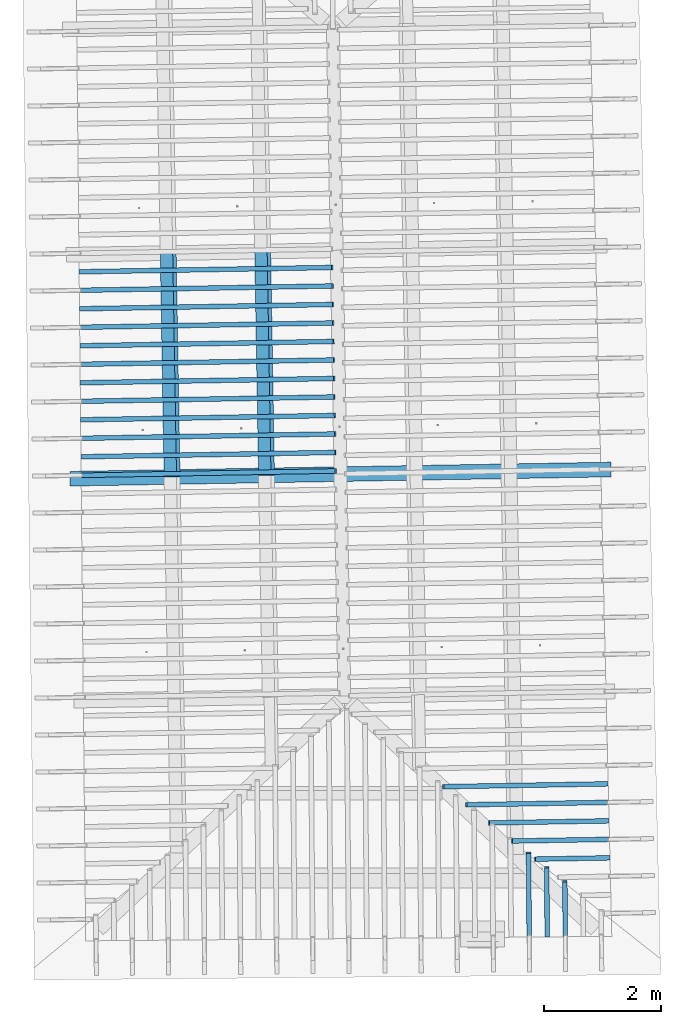
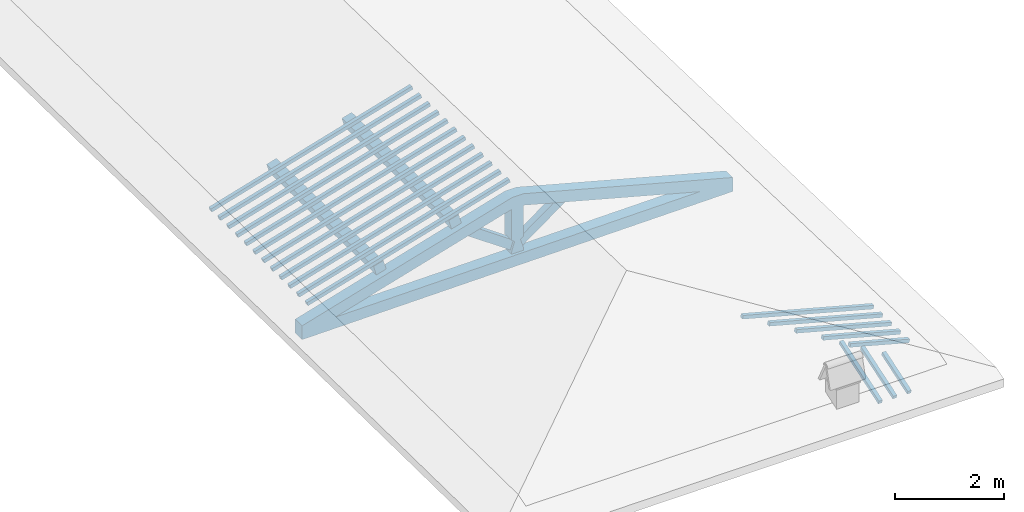
# One storey, part 4 of 19: 21 beams, 2 members, 3 elements without a shape of their own.
"""IFC4 building model written with IfcOpenShell, lengths in metres."""

from ifc_helpers import new_model, entity, si_unit, converted_unit, derived_unit, direction, frame, origin, place, context, subcontext, project, spatial, indexed_curve, outline, extrude, source, transform, mapped, material, type_object, type_shapes, element, aggregate, save


model = new_model("IFC4")

# Units and contexts
model_context = context("Model", 3, precision=1e-05, world=origin(), true_north=direction((6.123233995736766e-17, 1.0)))
body_context = subcontext(model_context, "Body", "Model", "MODEL_VIEW")
ifc_project = project(units=[si_unit("LENGTHUNIT", "METRE"), si_unit("AREAUNIT", "SQUARE_METRE"), si_unit("VOLUMEUNIT", "CUBIC_METRE"), converted_unit("PLANEANGLEUNIT", "DEGREE", entity("IfcPlaneAngleMeasure", 0.017453292519943278), si_unit("PLANEANGLEUNIT", "RADIAN"), dimensions=[0, 0, 0, 0, 0, 0, 0]), derived_unit("THERMALTRANSMITTANCEUNIT", [(si_unit("MASSUNIT", "GRAM", prefix="KILO"), 1), (si_unit("THERMODYNAMICTEMPERATUREUNIT", "KELVIN"), -1), (si_unit("TIMEUNIT", "SECOND"), -3)])], contexts=[model_context])

# Site, building, storey
site_placement = place(None, origin())
site = spatial("IfcSite", under=ifc_project, at=site_placement, CompositionType="ELEMENT")
building_placement = place(site_placement, origin())
building = spatial("IfcBuilding", under=site, at=building_placement, CompositionType="ELEMENT")
storey_placement = place(building_placement, frame((0.0, 0.0, 3.28)))
storey = spatial("IfcBuildingStorey", under=building, at=storey_placement, Name="Livello Copertura", CompositionType="ELEMENT", Elevation=3.28)

# Beam
ifc_material_1 = material(Name="Telaio", Category="Legno")
beam_type_1 = type_object("IfcBeamType", Name="con e 18x18 2", PredefinedType="BEAM", material=ifc_material_1)
shared_shape_1 = source(origin(), body_context, "Body", "SweptSolid", [
    extrude(outline(indexed_curve([(-0.16541753369488893, -2.7162453774766275), (0.08463069471711139, -2.716245377476629), (0.16842467663126645, 1.5495047236372541), (-0.01356084740826559, 1.9493040088108127), (-0.07407699024522271, 1.933682022505188), (-0.16541753369488893, -2.7162453774766275)], self_intersect=False)), frame((-2.713680684761416, -0.12500000000000352, 0.5116016056385222), z_axis=(0.0, 1.0, 0.0), x_axis=(0.24995178089011919, 0.0, -0.9682582853917946)), (0.0, 0.0, 1.0), 0.24999999999999992),
    extrude(outline(indexed_curve([(-2.718970219470431, -0.11203953208496607), (1.9318542149690596, -0.11203953208496614), (1.9486617037575076, -0.05184187166013539), (1.5525136616356172, 0.137960467915034), (-2.7140593608917554, 0.137960467915034), (-2.718970219470431, -0.11203953208496607)], self_intersect=False)), frame((2.7136806847614197, -0.12500000000000352, 0.5116016056385372), z_axis=(0.0, 1.0, 0.0), x_axis=(0.9631625667976574, 0.0, -0.2689198206152686)), (0.0, 0.0, 1.0), 0.24999999999999992),
    extrude(outline(indexed_curve([(-0.5601835339455478, -0.12499999999999746), (-0.49768353394554415, -0.12499999999999749), (-0.2968792817361453, -0.062499999999998515), (-0.2526268150406443, -0.12499999999999746), (0.4434537562213674, -0.12499999999999747), (0.4609040697695109, -0.06249999999999742), (0.7030153386769692, -0.12499999999999746), (0.7030153386769719, 0.1249999999999892), (0.46090406976954656, 0.06249999999999748), (0.4434537562214021, 0.12499999999999911), (-0.2526268150406462, 0.12499999999999915), (-0.29687928173614625, 0.06250000000000018), (-0.4976835339455446, 0.12499999999999908), (-0.5601835339455477, 0.12499999999999911), (-0.5601835339455478, -0.12499999999999746)], self_intersect=False)), frame((0.0, -0.12500000000000397, 0.647683533945542), z_axis=(0.0, 1.0, 0.0), x_axis=(0.0, 0.0, 1.0)), (0.0, 0.0, 1.0), 0.24999999999999992),
    extrude(outline(indexed_curve([(-4.548711713227807, -0.7192326477239056), (-4.505299668811077, -0.9654345859769559), (4.563794928678348, 0.6336914821578127), (4.520382884261614, 0.8798934204108596), (4.107604035615938, 0.7296542061691604), (3.82531022235883, 0.7573333565645375), (-3.8536390513249863, -0.5966725838775957), (-4.109441637550861, -0.7192326477239057), (-4.548711713227807, -0.7192326477239056)], self_intersect=False)), frame((0.0, -0.12500000000000175, -0.0440696120362346), z_axis=(0.0, -1.0, 0.0), x_axis=(0.984807753012208, 0.0, -0.17364817766693108)), (0.0, 0.0, -1.0), 0.24999999999999986),
    extrude(outline(indexed_curve([(0.20359543107977635, -0.4090841915047363), (0.4613119776404389, -0.4090841915047362), (-0.27535475240621304, 0.4973840166014553), (-0.3895526563140025, 0.3207843664080172), (0.20359543107977635, -0.4090841915047363)], self_intersect=False)), frame((0.5239678106288662, -0.07500000000000369, 0.5550133154913391), z_axis=(0.0, 1.0, 0.0), x_axis=(0.9631625667976574, 0.0, -0.2689198206152682)), (0.0, 0.0, 1.0), 0.14999999999999994),
    extrude(outline(indexed_curve([(-0.4613119776404252, -0.4090841915047199), (-0.20359543107976297, -0.4090841915047199), (0.38955265631398844, 0.3207843664080003), (0.2753547524061997, 0.4973840166014395), (-0.4613119776404252, -0.4090841915047199)], self_intersect=False)), frame((-0.5239678106288467, -0.07500000000000369, 0.5550133154913305), z_axis=(0.0, 1.0, 0.0), x_axis=(0.9631625667976591, 0.0, 0.2689198206152626)), (0.0, 0.0, 1.0), 0.15),
])
type_shapes(beam_type_1, [shared_shape_1])
beam_1_placement = place(storey_placement, frame((-0.17369111228995998, 4.725794282128985, -0.3317557506483801), z_axis=(0.0, 0.0, 1.0), x_axis=(0.9998547813867208, 0.017041600221598438, 0.0)))
element("IfcBeam", 1, at=beam_1_placement, inside=storey, type_object=beam_type_1, material=ifc_material_1, Name="con e 18x18 2", ObjectType="con e 18x18 2", PredefinedType="BEAM", context=body_context, shape_type="MappedRepresentation", body=[
    mapped(shared_shape_1, transform((0.0, 0.0, 0.0), scale=1.0)),
])

# Members
ifc_material_2 = material(Name="Legno - Legno da costruzione", Category="Legno")
member_type = type_object("IfcMemberType", Name="Legno:220x220", PredefinedType="PURLIN", material=ifc_material_2)
shared_shape_2 = source(origin(), body_context, "Body", "SweptSolid", [
    extrude(outline(indexed_curve([(-1.905999989737685, -0.11000000000000167), (1.9059999897376847, -0.11000000000000167), (1.905999989737685, 0.11000000000000167), (-1.905999989737685, 0.11000000000000167), (-1.905999989737685, -0.11000000000000167)], self_intersect=False)), frame((1.0262315338316342e-08, 0.0, -0.11000000000000543), z_axis=(0.0, 0.0, 1.0), x_axis=(-1.0, 0.0, 0.0)), (0.0, 0.0, 1.0), 0.21999999999999986),
])
type_shapes(member_type, [shared_shape_2])
for number, where, z_axis, x_axis, name in (
    (2, (-1.4665724231842459, 6.610303913730296, 0.8158581072187941), (-0.2688805697492535, -0.004594467440668277, 0.9631625667976581), (0.01708489701561056, -0.9998540424951863, 0.0), "Legno:220x220"),
    (3, (-3.0746343576136685, 6.582921611877691, 0.3668140609434398), (-0.2688805697492535, -0.004594467440668277, 0.9631625667976581), (0.01708489701561056, -0.9998540424951863, 0.0), "Legno:220x220"),
):
    element("IfcMember", number, at=place(storey_placement, frame(where, z_axis=z_axis, x_axis=x_axis)), inside=storey, type_object=member_type, material=ifc_material_2, Name=name, ObjectType="Legno:220x220", PredefinedType="PURLIN", context=body_context, shape_type="MappedRepresentation", body=[
        mapped(shared_shape_2, transform((0.0, 0.0, 0.0), scale=1.0)),
    ])

# Assembly, beams
assembly_1_placement = place(storey_placement, origin())
assembly_1 = element("IfcElementAssembly", 4, at=assembly_1_placement, inside=storey, Name="Sistema di travi strutturali:Sistema di travi strutturali", ObjectType="Sistema di travi strutturali:Sistema di travi strutturali", AssemblyPlace="NOTDEFINED", PredefinedType="BEAM_GRID")
beam_type_2 = type_object("IfcBeamType", Name="Legno:80x80", PredefinedType="JOIST", material=ifc_material_2)
shared_shape_3 = source(origin(), body_context, "Body", "SweptSolid", [
    extrude(outline(indexed_curve([(-2.233, -0.04000000000000169), (2.233, -0.04000000000000169), (2.233, 0.04000000000000169), (-2.233, 0.04000000000000169), (-2.233, -0.04000000000000169)], self_intersect=False)), frame((0.0, 0.0, -0.040000000000005476), z_axis=(0.0, 0.0, 1.0), x_axis=(-1.0, 0.0, 0.0)), (0.0, 0.0, 1.0), 0.07999999999999997),
])
type_shapes(beam_type_2, [shared_shape_3])
beam_2_placement = place(assembly_1_placement, frame((-2.463337274189889, 8.207578777476792, 0.7009532328972059), z_axis=(-0.2688805697492534, -0.004594467440668275, 0.9631625667976583), x_axis=(0.9630219859926786, 0.016455533263027115, 0.2689198206152653)))
beam_2 = element("IfcBeam", 5, at=beam_2_placement, type_object=beam_type_2, material=ifc_material_2, Name="Legno:80x80", ObjectType="Legno:80x80", PredefinedType="JOIST", context=body_context, shape_type="MappedRepresentation", body=[
    mapped(shared_shape_3, transform((0.0, 0.0, 0.0), scale=1.0)),
])
beam_type_3 = type_object("IfcBeamType", Name="Legno:80x80", PredefinedType="JOIST", material=ifc_material_2)
shared_shape_4 = source(origin(), body_context, "Body", "SweptSolid", [
    extrude(outline(indexed_curve([(-2.234, -0.04000000000000169), (2.234, -0.04000000000000169), (2.234, 0.04000000000000169), (-2.234, 0.04000000000000169), (-2.234, -0.04000000000000169)], self_intersect=False)), frame((0.0, 0.0, -0.040000000000005476), z_axis=(0.0, 0.0, 1.0), x_axis=(-1.0, 0.0, 0.0)), (0.0, 0.0, 1.0), 0.07999999999999997),
])
type_shapes(beam_type_3, [shared_shape_4])
beam_3_placement = place(assembly_1_placement, frame((-2.4591028111552244, 7.892605150076921, 0.7006328599372806), z_axis=(-0.2688805697492536, -0.0045944674406682776, 0.9631625667976582), x_axis=(0.9630219859926786, 0.016455533263027112, 0.26891982061526554)))
beam_3 = element("IfcBeam", 6, at=beam_3_placement, type_object=beam_type_3, material=ifc_material_2, Name="Legno:80x80", ObjectType="Legno:80x80", PredefinedType="JOIST", context=body_context, shape_type="MappedRepresentation", body=[
    mapped(shared_shape_4, transform((0.0, 0.0, 0.0), scale=1.0)),
])
beam_type_4 = type_object("IfcBeamType", Name="Legno:80x80", PredefinedType="JOIST", material=ifc_material_2)
shared_shape_5 = source(origin(), body_context, "Body", "SweptSolid", [
    extrude(outline(indexed_curve([(-2.235, -0.04000000000000169), (2.235, -0.04000000000000169), (2.235, 0.04000000000000169), (-2.235, 0.04000000000000169), (-2.235, -0.04000000000000169)], self_intersect=False)), frame((0.0, 0.0, -0.040000000000005476), z_axis=(0.0, 0.0, 1.0), x_axis=(-1.0, 0.0, 0.0)), (0.0, 0.0, 1.0), 0.07999999999999997),
])
type_shapes(beam_type_4, [shared_shape_5])
beam_4_placement = place(assembly_1_placement, frame((-2.4548683481205593, 7.5776315226770485, 0.7003124869773539), z_axis=(-0.2688805697492534, -0.004594467440668273, 0.9631625667976583), x_axis=(0.9630219859926786, 0.016455533263027122, 0.2689198206152653)))
beam_4 = element("IfcBeam", 7, at=beam_4_placement, type_object=beam_type_4, material=ifc_material_2, Name="Legno:80x80", ObjectType="Legno:80x80", PredefinedType="JOIST", context=body_context, shape_type="MappedRepresentation", body=[
    mapped(shared_shape_5, transform((0.0, 0.0, 0.0), scale=1.0)),
])
beam_type_5 = type_object("IfcBeamType", Name="Legno:80x80", PredefinedType="JOIST", material=ifc_material_2)
shared_shape_6 = source(origin(), body_context, "Body", "SweptSolid", [
    extrude(outline(indexed_curve([(-2.2365, -0.04000000000000169), (2.2365, -0.04000000000000169), (2.2365, 0.04000000000000169), (-2.2365, 0.04000000000000169), (-2.2365, -0.04000000000000169)], self_intersect=False)), frame((0.0, 0.0, -0.040000000000005476), z_axis=(0.0, 0.0, 1.0), x_axis=(-1.0, 0.0, 0.0)), (0.0, 0.0, 1.0), 0.07999999999999997),
])
type_shapes(beam_type_5, [shared_shape_6])
beam_5_placement = place(assembly_1_placement, frame((-2.4506338850858955, 7.262657895277173, 0.6999921140174283), z_axis=(-0.2688805697492536, -0.004594467440668277, 0.9631625667976583), x_axis=(0.9630219859926786, 0.01645553326302712, 0.26891982061526554)))
beam_5 = element("IfcBeam", 8, at=beam_5_placement, type_object=beam_type_5, material=ifc_material_2, Name="Legno:80x80", ObjectType="Legno:80x80", PredefinedType="JOIST", context=body_context, shape_type="MappedRepresentation", body=[
    mapped(shared_shape_6, transform((0.0, 0.0, 0.0), scale=1.0)),
])
beam_type_6 = type_object("IfcBeamType", Name="Legno:80x80", PredefinedType="JOIST", material=ifc_material_2)
shared_shape_7 = source(origin(), body_context, "Body", "SweptSolid", [
    extrude(outline(indexed_curve([(-2.2375, -0.04000000000000169), (2.2375, -0.04000000000000169), (2.2375, 0.04000000000000169), (-2.2375, 0.04000000000000169), (-2.2375, -0.04000000000000169)], self_intersect=False)), frame((0.0, 0.0, -0.040000000000005476), z_axis=(0.0, 0.0, 1.0), x_axis=(-1.0, 0.0, 0.0)), (0.0, 0.0, 1.0), 0.07999999999999997),
])
type_shapes(beam_type_6, [shared_shape_7])
beam_6_placement = place(assembly_1_placement, frame((-2.4463994220512304, 6.947684267877299, 0.6996717410575017), z_axis=(-0.2688805697492535, -0.004594467440668277, 0.9631625667976583), x_axis=(0.9630219859926786, 0.016455533263027143, 0.2689198206152654)))
beam_6 = element("IfcBeam", 9, at=beam_6_placement, type_object=beam_type_6, material=ifc_material_2, Name="Legno:80x80", ObjectType="Legno:80x80", PredefinedType="JOIST", context=body_context, shape_type="MappedRepresentation", body=[
    mapped(shared_shape_7, transform((0.0, 0.0, 0.0), scale=1.0)),
])
beam_type_7 = type_object("IfcBeamType", Name="Legno:80x80", PredefinedType="JOIST", material=ifc_material_2)
shared_shape_8 = source(origin(), body_context, "Body", "SweptSolid", [
    extrude(outline(indexed_curve([(-2.239, -0.04000000000000169), (2.239, -0.04000000000000169), (2.239, 0.04000000000000169), (-2.239, 0.04000000000000169), (-2.239, -0.04000000000000169)], self_intersect=False)), frame((0.0, 0.0, -0.040000000000005476), z_axis=(0.0, 0.0, 1.0), x_axis=(-1.0, 0.0, 0.0)), (0.0, 0.0, 1.0), 0.07999999999999997),
])
type_shapes(beam_type_7, [shared_shape_8])
beam_7_placement = place(assembly_1_placement, frame((-2.4421649590165644, 6.632710640477425, 0.6993513680975754), z_axis=(-0.26888056974925356, -0.0045944674406682776, 0.9631625667976583), x_axis=(0.9630219859926786, 0.016455533263027147, 0.2689198206152655)))
beam_7 = element("IfcBeam", 10, at=beam_7_placement, type_object=beam_type_7, material=ifc_material_2, Name="Legno:80x80", ObjectType="Legno:80x80", PredefinedType="JOIST", context=body_context, shape_type="MappedRepresentation", body=[
    mapped(shared_shape_8, transform((0.0, 0.0, 0.0), scale=1.0)),
])
beam_type_8 = type_object("IfcBeamType", Name="Legno:80x80", PredefinedType="JOIST", material=ifc_material_2)
shared_shape_9 = source(origin(), body_context, "Body", "SweptSolid", [
    extrude(outline(indexed_curve([(-2.24, -0.04000000000000169), (2.24, -0.04000000000000169), (2.24, 0.04000000000000169), (-2.24, 0.04000000000000169), (-2.24, -0.04000000000000169)], self_intersect=False)), frame((0.0, 0.0, -0.040000000000005476), z_axis=(0.0, 0.0, 1.0), x_axis=(-1.0, 0.0, 0.0)), (0.0, 0.0, 1.0), 0.07999999999999997),
])
type_shapes(beam_type_8, [shared_shape_9])
beam_8_placement = place(assembly_1_placement, frame((-2.4379304959819006, 6.317737013077552, 0.6990309951376489), z_axis=(-0.2688805697492535, -0.004594467440668277, 0.9631625667976583), x_axis=(0.9630219859926786, 0.016455533263027153, 0.2689198206152654)))
beam_8 = element("IfcBeam", 11, at=beam_8_placement, type_object=beam_type_8, material=ifc_material_2, Name="Legno:80x80", ObjectType="Legno:80x80", PredefinedType="JOIST", context=body_context, shape_type="MappedRepresentation", body=[
    mapped(shared_shape_9, transform((0.0, 0.0, 0.0), scale=1.0)),
])
beam_type_9 = type_object("IfcBeamType", Name="Legno:80x80", PredefinedType="JOIST", material=ifc_material_2)
shared_shape_10 = source(origin(), body_context, "Body", "SweptSolid", [
    extrude(outline(indexed_curve([(-2.241, -0.04000000000000169), (2.241, -0.04000000000000169), (2.241, 0.04000000000000169), (-2.241, 0.04000000000000169), (-2.241, -0.04000000000000169)], self_intersect=False)), frame((0.0, 0.0, -0.040000000000005476), z_axis=(0.0, 0.0, 1.0), x_axis=(-1.0, 0.0, 0.0)), (0.0, 0.0, 1.0), 0.07999999999999997),
])
type_shapes(beam_type_9, [shared_shape_10])
beam_9_placement = place(assembly_1_placement, frame((-2.4336960329472364, 6.002763385677678, 0.6987106221777234), z_axis=(-0.26888056974925356, -0.004594467440668277, 0.9631625667976583), x_axis=(0.9630219859926786, 0.01645553326302716, 0.2689198206152655)))
beam_9 = element("IfcBeam", 12, at=beam_9_placement, type_object=beam_type_9, material=ifc_material_2, Name="Legno:80x80", ObjectType="Legno:80x80", PredefinedType="JOIST", context=body_context, shape_type="MappedRepresentation", body=[
    mapped(shared_shape_10, transform((0.0, 0.0, 0.0), scale=1.0)),
])
beam_type_10 = type_object("IfcBeamType", Name="Legno:80x80", PredefinedType="JOIST", material=ifc_material_2)
shared_shape_11 = source(origin(), body_context, "Body", "SweptSolid", [
    extrude(outline(indexed_curve([(-2.2425, -0.04000000000000169), (2.2425, -0.04000000000000169), (2.2425, 0.04000000000000169), (-2.2425, 0.04000000000000169), (-2.2425, -0.04000000000000169)], self_intersect=False)), frame((0.0, 0.0, -0.040000000000005476), z_axis=(0.0, 0.0, 1.0), x_axis=(-1.0, 0.0, 0.0)), (0.0, 0.0, 1.0), 0.07999999999999997),
])
type_shapes(beam_type_10, [shared_shape_11])
beam_10_placement = place(assembly_1_placement, frame((-2.4294615699125717, 5.687789758277803, 0.6983902492177972), z_axis=(-0.26888056974925345, -0.004594467440668275, 0.9631625667976583), x_axis=(0.9630219859926787, 0.01645553326302716, 0.26891982061526537)))
beam_10 = element("IfcBeam", 13, at=beam_10_placement, type_object=beam_type_10, material=ifc_material_2, Name="Legno:80x80", ObjectType="Legno:80x80", PredefinedType="JOIST", context=body_context, shape_type="MappedRepresentation", body=[
    mapped(shared_shape_11, transform((0.0, 0.0, 0.0), scale=1.0)),
])
beam_type_11 = type_object("IfcBeamType", Name="Legno:80x80", PredefinedType="JOIST", material=ifc_material_2)
shared_shape_12 = source(origin(), body_context, "Body", "SweptSolid", [
    extrude(outline(indexed_curve([(-2.2435, -0.04000000000000169), (2.2435, -0.04000000000000169), (2.2435, 0.04000000000000169), (-2.2435, 0.04000000000000169), (-2.2435, -0.04000000000000169)], self_intersect=False)), frame((0.0, 0.0, -0.040000000000005476), z_axis=(0.0, 0.0, 1.0), x_axis=(-1.0, 0.0, 0.0)), (0.0, 0.0, 1.0), 0.07999999999999997),
])
type_shapes(beam_type_11, [shared_shape_12])
beam_11_placement = place(assembly_1_placement, frame((-2.4252271068779065, 5.372816130877929, 0.69806987625787), z_axis=(-0.26888056974925356, -0.004594467440668278, 0.9631625667976582), x_axis=(0.9630219859926786, 0.016455533263027174, 0.2689198206152655)))
beam_11 = element("IfcBeam", 14, at=beam_11_placement, type_object=beam_type_11, material=ifc_material_2, Name="Legno:80x80", ObjectType="Legno:80x80", PredefinedType="JOIST", context=body_context, shape_type="MappedRepresentation", body=[
    mapped(shared_shape_12, transform((0.0, 0.0, 0.0), scale=1.0)),
])
beam_type_12 = type_object("IfcBeamType", Name="Legno:80x80", PredefinedType="JOIST", material=ifc_material_2)
shared_shape_13 = source(origin(), body_context, "Body", "SweptSolid", [
    extrude(outline(indexed_curve([(-2.2445, -0.04000000000000169), (2.2445, -0.04000000000000169), (2.2445, 0.04000000000000169), (-2.2445, 0.04000000000000169), (-2.2445, -0.04000000000000169)], self_intersect=False)), frame((0.0, 0.0, -0.040000000000005476), z_axis=(0.0, 0.0, 1.0), x_axis=(-1.0, 0.0, 0.0)), (0.0, 0.0, 1.0), 0.07999999999999997),
])
type_shapes(beam_type_12, [shared_shape_13])
beam_12_placement = place(assembly_1_placement, frame((-2.420992643843241, 5.0578425034780565, 0.6977495032979448), z_axis=(-0.2688805697492535, -0.0045944674406682776, 0.9631625667976582), x_axis=(0.9630219859926786, 0.016455533263027178, 0.2689198206152654)))
beam_12 = element("IfcBeam", 15, at=beam_12_placement, type_object=beam_type_12, material=ifc_material_2, Name="Legno:80x80", ObjectType="Legno:80x80", PredefinedType="JOIST", context=body_context, shape_type="MappedRepresentation", body=[
    mapped(shared_shape_13, transform((0.0, 0.0, 0.0), scale=1.0)),
])
beam_type_13 = type_object("IfcBeamType", Name="Legno:80x80", PredefinedType="JOIST", material=ifc_material_2)
shared_shape_14 = source(origin(), body_context, "Body", "SweptSolid", [
    extrude(outline(indexed_curve([(-2.246, -0.04000000000000169), (2.246, -0.04000000000000169), (2.246, 0.04000000000000169), (-2.246, 0.04000000000000169), (-2.246, -0.04000000000000169)], self_intersect=False)), frame((0.0, 0.0, -0.040000000000005476), z_axis=(0.0, 0.0, 1.0), x_axis=(-1.0, 0.0, 0.0)), (0.0, 0.0, 1.0), 0.07999999999999997),
])
type_shapes(beam_type_13, [shared_shape_14])
beam_13_placement = place(assembly_1_placement, frame((-2.4167581808085763, 4.742868876078184, 0.697429130338018), z_axis=(-0.2688805697492535, -0.004594467440668277, 0.9631625667976583), x_axis=(0.9630219859926786, 0.01645553326302694, 0.2689198206152654)))
beam_13 = element("IfcBeam", 16, at=beam_13_placement, type_object=beam_type_13, material=ifc_material_2, Name="Legno:80x80", ObjectType="Legno:80x80", PredefinedType="JOIST", context=body_context, shape_type="MappedRepresentation", body=[
    mapped(shared_shape_14, transform((0.0, 0.0, 0.0), scale=1.0)),
])
aggregate(assembly_1, [beam_2, beam_3, beam_4, beam_5, beam_6, beam_7, beam_8, beam_9, beam_10, beam_11, beam_12, beam_13])

assembly_2_placement = place(storey_placement, origin())
assembly_2 = element("IfcElementAssembly", 17, at=assembly_2_placement, inside=storey, Name="Sistema di travi strutturali:Sistema di travi strutturali", ObjectType="Sistema di travi strutturali:Sistema di travi strutturali", AssemblyPlace="NOTDEFINED", PredefinedType="BEAM_GRID")
beam_type_14 = type_object("IfcBeamType", Name="Legno:80x80", PredefinedType="JOIST", material=ifc_material_2)
shared_shape_15 = source(origin(), body_context, "Body", "SweptSolid", [
    extrude(outline(indexed_curve([(-0.6570000000000001, -0.04000000000000169), (0.6570000000000001, -0.04000000000000169), (0.6570000000000001, 0.04000000000000169), (-0.6570000000000001, 0.04000000000000169), (-0.6570000000000001, -0.04000000000000169)], self_intersect=False)), frame((0.0, 0.0, -0.040000000000005476), z_axis=(0.0, 0.0, 1.0), x_axis=(-1.0, 0.0, 0.0)), (0.0, 0.0, 1.0), 0.07999999999999997),
])
type_shapes(beam_type_14, [shared_shape_15])
beam_14_placement = place(assembly_2_placement, frame((3.769792716915178, -1.8182949555790597, 0.25399191661763165), z_axis=(0.2688805697492537, 0.004594467440668279, 0.9631625667976582), x_axis=(-0.9630219859926785, -0.01645553326302795, 0.2689198206152656)))
beam_14 = element("IfcBeam", 18, at=beam_14_placement, type_object=beam_type_14, material=ifc_material_2, Name="Legno:80x80", ObjectType="Legno:80x80", PredefinedType="JOIST", context=body_context, shape_type="MappedRepresentation", body=[
    mapped(shared_shape_15, transform((0.0, 0.0, 0.0), scale=1.0)),
])
beam_type_15 = type_object("IfcBeamType", Name="Legno:80x80", PredefinedType="JOIST", material=ifc_material_2)
shared_shape_16 = source(origin(), body_context, "Body", "SweptSolid", [
    extrude(outline(indexed_curve([(-0.8560000000000001, -0.04000000000000169), (0.8560000000000001, -0.04000000000000169), (0.8560000000000001, 0.04000000000000169), (-0.8560000000000001, 0.04000000000000169), (-0.8560000000000001, -0.04000000000000169)], self_intersect=False)), frame((0.0, 0.0, -0.040000000000005476), z_axis=(0.0, 0.0, 1.0), x_axis=(-1.0, 0.0, 0.0)), (0.0, 0.0, 1.0), 0.07999999999999997),
])
type_shapes(beam_type_15, [shared_shape_16])
beam_15_placement = place(assembly_2_placement, frame((3.570779191815584, -1.5066495941807638, 0.30806277375627633), z_axis=(0.26888056974925334, 0.004594467440668276, 0.9631625667976583), x_axis=(-0.9630219859926786, -0.016455533263027972, 0.26891982061526526)))
beam_15 = element("IfcBeam", 19, at=beam_15_placement, type_object=beam_type_15, material=ifc_material_2, Name="Legno:80x80", ObjectType="Legno:80x80", PredefinedType="JOIST", context=body_context, shape_type="MappedRepresentation", body=[
    mapped(shared_shape_16, transform((0.0, 0.0, 0.0), scale=1.0)),
])
beam_type_16 = type_object("IfcBeamType", Name="Legno:80x80", PredefinedType="JOIST", material=ifc_material_2)
shared_shape_17 = source(origin(), body_context, "Body", "SweptSolid", [
    extrude(outline(indexed_curve([(-1.055, -0.04000000000000169), (1.055, -0.04000000000000169), (1.055, 0.04000000000000169), (-1.055, 0.04000000000000169), (-1.055, -0.04000000000000169)], self_intersect=False)), frame((0.0, 0.0, -0.040000000000005476), z_axis=(0.0, 0.0, 1.0), x_axis=(-1.0, 0.0, 0.0)), (0.0, 0.0, 1.0), 0.07999999999999997),
])
type_shapes(beam_type_16, [shared_shape_17])
beam_16_placement = place(assembly_2_placement, frame((3.3717656667159885, -1.1950042327824668, 0.36213363089492123), z_axis=(0.2688805697492536, 0.004594467440668277, 0.9631625667976582), x_axis=(-0.9630219859926785, -0.016455533263027917, 0.26891982061526554)))
beam_16 = element("IfcBeam", 20, at=beam_16_placement, type_object=beam_type_16, material=ifc_material_2, Name="Legno:80x80", ObjectType="Legno:80x80", PredefinedType="JOIST", context=body_context, shape_type="MappedRepresentation", body=[
    mapped(shared_shape_17, transform((0.0, 0.0, 0.0), scale=1.0)),
])
beam_type_17 = type_object("IfcBeamType", Name="Legno:80x80", PredefinedType="JOIST", material=ifc_material_2)
shared_shape_18 = source(origin(), body_context, "Body", "SweptSolid", [
    extrude(outline(indexed_curve([(-1.254, -0.04000000000000169), (1.254, -0.04000000000000169), (1.254, 0.04000000000000169), (-1.254, 0.04000000000000169), (-1.254, -0.04000000000000169)], self_intersect=False)), frame((0.0, 0.0, -0.040000000000005476), z_axis=(0.0, 0.0, 1.0), x_axis=(-1.0, 0.0, 0.0)), (0.0, 0.0, 1.0), 0.07999999999999997),
])
type_shapes(beam_type_17, [shared_shape_18])
beam_17_placement = place(assembly_2_placement, frame((3.172752141616396, -0.883358871384171, 0.41620448803356624), z_axis=(0.26888056974925334, 0.004594467440668274, 0.9631625667976583), x_axis=(-0.9630219859926787, -0.01645553326302789, 0.26891982061526526)))
beam_17 = element("IfcBeam", 21, at=beam_17_placement, type_object=beam_type_17, material=ifc_material_2, Name="Legno:80x80", ObjectType="Legno:80x80", PredefinedType="JOIST", context=body_context, shape_type="MappedRepresentation", body=[
    mapped(shared_shape_18, transform((0.0, 0.0, 0.0), scale=1.0)),
])
beam_type_18 = type_object("IfcBeamType", Name="Legno:80x80", PredefinedType="JOIST", material=ifc_material_2)
shared_shape_19 = source(origin(), body_context, "Body", "SweptSolid", [
    extrude(outline(indexed_curve([(-1.453, -0.04000000000000169), (1.453, -0.04000000000000169), (1.453, 0.04000000000000169), (-1.453, 0.04000000000000169), (-1.453, -0.04000000000000169)], self_intersect=False)), frame((0.0, 0.0, -0.040000000000005476), z_axis=(0.0, 0.0, 1.0), x_axis=(-1.0, 0.0, 0.0)), (0.0, 0.0, 1.0), 0.07999999999999997),
])
type_shapes(beam_type_18, [shared_shape_19])
beam_18_placement = place(assembly_2_placement, frame((2.9737386165168003, -0.5717135099858742, 0.4702753451722106), z_axis=(0.2688805697492536, 0.004594467440668278, 0.9631625667976582), x_axis=(-0.9630219859926786, -0.01645553326302788, 0.26891982061526554)))
beam_18 = element("IfcBeam", 22, at=beam_18_placement, type_object=beam_type_18, material=ifc_material_2, Name="Legno:80x80", ObjectType="Legno:80x80", PredefinedType="JOIST", context=body_context, shape_type="MappedRepresentation", body=[
    mapped(shared_shape_19, transform((0.0, 0.0, 0.0), scale=1.0)),
])
aggregate(assembly_2, [beam_14, beam_15, beam_16, beam_17, beam_18])

assembly_3_placement = place(storey_placement, origin())
assembly_3 = element("IfcElementAssembly", 23, at=assembly_3_placement, inside=storey, Name="Sistema di travi strutturali:Sistema di travi strutturali", ObjectType="Sistema di travi strutturali:Sistema di travi strutturali", AssemblyPlace="NOTDEFINED", PredefinedType="BEAM_GRID")
beam_type_19 = type_object("IfcBeamType", Name="Legno:80x80", PredefinedType="JOIST", material=ifc_material_2)
shared_shape_20 = source(origin(), body_context, "Body", "SweptSolid", [
    extrude(outline(indexed_curve([(-0.491, -0.04000000000000169), (0.491, -0.04000000000000169), (0.491, 0.04000000000000169), (-0.491, 0.04000000000000169), (-0.491, -0.04000000000000169)], self_intersect=False)), frame((0.0, 0.0, -0.040000000000005476), z_axis=(0.0, 0.0, 1.0), x_axis=(-1.0, 0.0, 0.0)), (0.0, 0.0, 1.0), 0.07999999999999997),
])
type_shapes(beam_type_19, [shared_shape_20])
beam_19_placement = place(assembly_3_placement, frame((3.6493934248076494, -2.6735746459757936, 0.13455434537262434), z_axis=(0.00339332276243599, -0.3255504700615087, 0.9455185755993166), x_axis=(-0.007932350194779501, 0.9454855083215803, 0.32556755270491905)))
beam_19 = element("IfcBeam", 24, at=beam_19_placement, type_object=beam_type_19, material=ifc_material_2, Name="Legno:80x80", ObjectType="Legno:80x80", PredefinedType="JOIST", context=body_context, shape_type="MappedRepresentation", body=[
    mapped(shared_shape_20, transform((0.0, 0.0, 0.0), scale=1.0)),
])
beam_type_20 = type_object("IfcBeamType", Name="Legno:80x80", PredefinedType="JOIST", material=ifc_material_2)
shared_shape_21 = source(origin(), body_context, "Body", "SweptSolid", [
    extrude(outline(indexed_curve([(-0.6215, -0.04000000000000169), (0.6215, -0.04000000000000169), (0.6215, 0.04000000000000169), (-0.6215, 0.04000000000000169), (-0.6215, -0.04000000000000169)], self_intersect=False)), frame((0.0, 0.0, -0.040000000000005476), z_axis=(0.0, 0.0, 1.0), x_axis=(-1.0, 0.0, 0.0)), (0.0, 0.0, 1.0), 0.07999999999999997),
])
type_shapes(beam_type_20, [shared_shape_21])
beam_20_placement = place(assembly_3_placement, frame((3.3410693042824318, -2.552787046160873, 0.17724912070070065), z_axis=(0.00339332276243599, -0.3255504700615086, 0.9455185755993168), x_axis=(-0.007932350194779577, 0.9454855083215803, 0.325567552704919)))
beam_20 = element("IfcBeam", 25, at=beam_20_placement, type_object=beam_type_20, material=ifc_material_2, Name="Legno:80x80", ObjectType="Legno:80x80", PredefinedType="JOIST", context=body_context, shape_type="MappedRepresentation", body=[
    mapped(shared_shape_21, transform((0.0, 0.0, 0.0), scale=1.0)),
])
beam_type_21 = type_object("IfcBeamType", Name="Legno:80x80", PredefinedType="JOIST", material=ifc_material_2)
shared_shape_22 = source(origin(), body_context, "Body", "SweptSolid", [
    extrude(outline(indexed_curve([(-0.752, -0.04000000000000169), (0.752, -0.04000000000000169), (0.752, 0.04000000000000169), (-0.752, 0.04000000000000169), (-0.752, -0.04000000000000169)], self_intersect=False)), frame((0.0, 0.0, -0.040000000000005476), z_axis=(0.0, 0.0, 1.0), x_axis=(-1.0, 0.0, 0.0)), (0.0, 0.0, 1.0), 0.07999999999999997),
])
type_shapes(beam_type_21, [shared_shape_22])
beam_21_placement = place(assembly_3_placement, frame((3.032745183757215, -2.4319994463459516, 0.21994389602877618), z_axis=(0.0033933227624359896, -0.3255504700615087, 0.9455185755993166), x_axis=(-0.007932350194779633, 0.9454855083215803, 0.32556755270491905)))
beam_21 = element("IfcBeam", 26, at=beam_21_placement, type_object=beam_type_21, material=ifc_material_2, Name="Legno:80x80", ObjectType="Legno:80x80", PredefinedType="JOIST", context=body_context, shape_type="MappedRepresentation", body=[
    mapped(shared_shape_22, transform((0.0, 0.0, 0.0), scale=1.0)),
])
aggregate(assembly_3, [beam_19, beam_20, beam_21])

save(model, "model.ifc")
